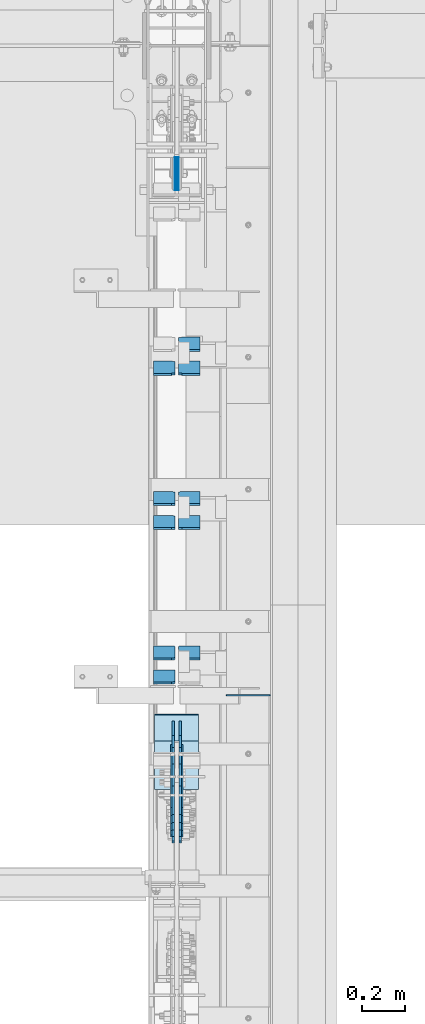
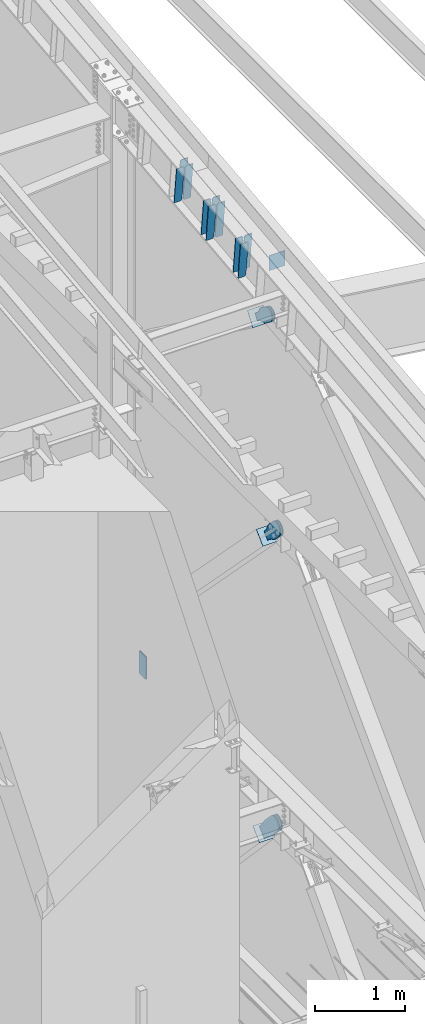
# One storey, part 1033 of 1179: 22 plates, 12 elements without a shape of their own.
"""IFC2X3 building model written with IfcOpenShell, lengths in millimetres."""

import ifcopenshell
import ifcopenshell.guid

model = None  # the IFC model being written
_history = None  # IfcOwnerHistory: only IFC2X3 demands one
_inside = {}  # id of a spatial element -> (the spatial element, [elements in it])
_under = {}  # id of a project, library or spatial element -> (it, [spatial elements below it])
_declared = {}  # id of a project -> (the project, [libraries it declares])
_typed = {}  # id of a type object -> (the type object, [elements of that type])
_made_of = {}  # id of a material, layer set ... -> (it, [elements and type objects made of it])


def new_model(schema):
    """Start an empty IFC model of exactly this schema.

    Asked for "IFC4X3", IfcOpenShell would pick the latest addendum, in which some entities
    have other attributes; the version numbers below select the first issue.
    IFC2X3 requires an IfcOwnerHistory on every rooted entity: one is made here for all.
    """
    global model, _history
    if schema == "IFC4X3":
        model = ifcopenshell.file(schema_version=(4, 3, 0, 0))
    else:
        model = ifcopenshell.file(schema=schema)
    _inside.clear()
    _under.clear()
    _declared.clear()
    _typed.clear()
    _made_of.clear()
    _history = None
    if model.schema == "IFC2X3":
        org = make("IfcOrganization", Name="unknown")
        user = make(
            "IfcPersonAndOrganization",
            ThePerson=make("IfcPerson", FamilyName="unknown"),
            TheOrganization=org,
        )
        app = make(
            "IfcApplication",
            ApplicationDeveloper=org,
            Version="unknown",
            ApplicationFullName="unknown",
            ApplicationIdentifier="unknown",
        )
        _history = make(
            "IfcOwnerHistory",
            OwningUser=user,
            OwningApplication=app,
            ChangeAction="ADDED",
            CreationDate=0,
        )
    return model


def make(cls, **values):
    """One entity of the class cls with the attributes given. An attribute that is None is left unset."""
    return model.create_entity(
        cls, **{name: value for name, value in values.items() if value is not None}
    )


def rooted(cls, **values):
    """An entity with a GlobalId (a new one), such as an element, a storey or a relation."""
    return make(cls, GlobalId=ifcopenshell.guid.new(), OwnerHistory=_history, **values)


def si_unit(unit_type, name, prefix=None):
    """IfcSIUnit, for example si_unit("LENGTHUNIT", "METRE", prefix="MILLI")."""
    return make("IfcSIUnit", UnitType=unit_type, Prefix=prefix, Name=name)


def assignment(units):
    """IfcUnitAssignment: the units of a project."""
    return None if units is None else make("IfcUnitAssignment", Units=units)


def point(xyz):
    """IfcCartesianPoint."""
    return None if xyz is None else make("IfcCartesianPoint", Coordinates=xyz)


def direction(xyz):
    """IfcDirection."""
    return None if xyz is None else make("IfcDirection", DirectionRatios=xyz)


def frame(location, z_axis=None, x_axis=None):
    """IfcAxis2Placement3D, a coordinate frame: its origin and axes. An axis left out is left unset."""
    return make(
        "IfcAxis2Placement3D",
        Location=point(location),
        Axis=direction(z_axis),
        RefDirection=direction(x_axis),
    )


def origin_with_axes():
    """The frame at (0, 0, 0) with the z axis (0, 0, 1) and the x axis (1, 0, 0) written out."""
    return frame((0.0, 0.0, 0.0), z_axis=(0.0, 0.0, 1.0), x_axis=(1.0, 0.0, 0.0))


def place(relative_to, where):
    """IfcLocalPlacement: puts the frame where relative to a parent placement (None: the world)."""
    return make(
        "IfcLocalPlacement", PlacementRelTo=relative_to, RelativePlacement=where
    )


def context(
    kind, dimensions, precision=None, world=None, true_north=None, identifier=None
):
    """IfcGeometricRepresentationContext, for example the 3D "Model" context."""
    return make(
        "IfcGeometricRepresentationContext",
        ContextIdentifier=identifier,
        ContextType=kind,
        CoordinateSpaceDimension=dimensions,
        Precision=precision,
        WorldCoordinateSystem=world,
        TrueNorth=true_north,
    )


def subcontext(parent, identifier, kind, view, scale=None):
    """IfcGeometricRepresentationSubContext, for example "Body" below "Model"."""
    return make(
        "IfcGeometricRepresentationSubContext",
        ContextIdentifier=identifier,
        ContextType=kind,
        ParentContext=parent,
        TargetScale=scale,
        TargetView=view,
    )


def project(units=None, contexts=None):
    """IfcProject with its units and contexts."""
    return rooted(
        "IfcProject",
        Name="project",
        RepresentationContexts=contexts,
        UnitsInContext=assignment(units),
    )


def spatial(cls, under=None, at=None, **own):
    """A site, building, storey or space (cls), placed at a placement, below another one or the project."""
    s = rooted(cls, ObjectPlacement=at, **own)
    if under is not None:
        _under.setdefault(under.id(), (under, []))[1].append(s)
    return s


def faces_of(points, faces, orient=None, outer=None):
    """IfcFace entities. A face is a list of loops; a loop is a list of indices into points, from 0.

    orient and outer hold one flag for each loop. By default every Orientation is true, the
    first loop of a face is its IfcFaceOuterBound and the others are IfcFaceBound.
    """
    made = []
    for i, loops in enumerate(faces):
        bounds = []
        for j, loop in enumerate(loops):
            is_outer = j == 0 if outer is None else outer[i][j]
            bounds.append(
                make(
                    "IfcFaceOuterBound" if is_outer else "IfcFaceBound",
                    Bound=make("IfcPolyLoop", Polygon=[points[k] for k in loop]),
                    Orientation=True if orient is None else orient[i][j],
                )
            )
        made.append(make("IfcFace", Bounds=bounds))
    return made


def faceted_brep(points, faces, orient=None, outer=None, voids=None):
    """IfcFacetedBrep: a solid bounded by flat faces; with voids (closed shells), ...WithVoids."""
    shared = [point(p) for p in points]
    hull = make("IfcClosedShell", CfsFaces=faces_of(shared, faces, orient, outer))
    if voids is None:
        return make("IfcFacetedBrep", Outer=hull)
    return make(
        "IfcFacetedBrepWithVoids",
        Outer=hull,
        Voids=[
            make(cls, CfsFaces=faces_of(shared, fs, o, b)) for cls, fs, o, b in voids
        ],
    )


def shape(context_of_items, identifier, shape_type, items):
    """IfcShapeRepresentation: the items that make up one representation, for example the "Body"."""
    return make(
        "IfcShapeRepresentation",
        ContextOfItems=context_of_items,
        RepresentationIdentifier=identifier,
        RepresentationType=shape_type,
        Items=items,
    )


def material(Name=None, Category=None):
    """IfcMaterial."""
    return make("IfcMaterial", Name=Name, Category=Category)


def made_of(thing, what):
    """Note that an element or type object is made of a material, layer set ...; save() writes the relation."""
    if what is not None:
        _made_of.setdefault(what.id(), (what, []))[1].append(thing)
    return thing


def type_object(cls, material=None, **own):
    """A type object (cls), such as IfcWallType, which elements share."""
    return made_of(rooted(cls, **own), material)


def element(
    cls,
    number,
    at=None,
    inside=None,
    cuts=None,
    type_object=None,
    material=None,
    context=None,
    identifier="Body",
    shape_type=None,
    held_by="IfcProductDefinitionShape",
    body=None,
    shapes=None,
    **own,
):
    """One element of the class cls, such as IfcWall. Its Tag is "e" and its number.

    at: its placement. inside: the storey or other place that contains it. cuts: it is an
    opening in that element (IfcRelVoidsElement). A single representation is given by context,
    identifier, shape_type and body (its items); several are given by shapes. held_by: the class
    of the entity that holds the representations. save() writes the other relations.
    """
    e = rooted(cls, Tag="e%d" % number, ObjectPlacement=at, **own)
    if body is not None:
        shapes = [shape(context, identifier, shape_type, body)]
    if shapes is not None:
        e.Representation = make(held_by, Representations=shapes)
    if inside is not None:
        _inside.setdefault(inside.id(), (inside, []))[1].append(e)
    if cuts is not None:
        rooted(
            "IfcRelVoidsElement", RelatingBuildingElement=cuts, RelatedOpeningElement=e
        )
    if type_object is not None:
        _typed.setdefault(type_object.id(), (type_object, []))[1].append(e)
    return made_of(e, material)


def aggregate(whole, parts):
    """IfcRelAggregates: a whole, such as a stair, and the parts it consists of."""
    return rooted("IfcRelAggregates", RelatingObject=whole, RelatedObjects=parts)


def save(model, path):
    """Write the relations noted so far, then the file.

    IfcRelAggregates (storeys below a building ...), IfcRelContainedInSpatialStructure (elements
    in a storey), IfcRelDefinesByType, IfcRelAssociatesMaterial and IfcRelDeclares: one each for
    every whole, place, type object, material and project.
    """
    for whole, parts in _under.values():
        aggregate(whole, parts)
    for where, things in _inside.values():
        rooted(
            "IfcRelContainedInSpatialStructure",
            RelatedElements=things,
            RelatingStructure=where,
        )
    for kind, things in _typed.values():
        rooted("IfcRelDefinesByType", RelatedObjects=things, RelatingType=kind)
    for what, things in _made_of.values():
        rooted("IfcRelAssociatesMaterial", RelatedObjects=things, RelatingMaterial=what)
    for by, libraries in _declared.values():
        rooted("IfcRelDeclares", RelatingContext=by, RelatedDefinitions=libraries)
    model.write(path)


model = new_model("IFC2X3")

# Units and contexts
model_context = context("Model", 3, precision=1e-05, world=origin_with_axes())
body_context = subcontext(model_context, "Body", "Model", "MODEL_VIEW")
ifc_project = project(units=[si_unit("LENGTHUNIT", "METRE", prefix="MILLI"), si_unit("AREAUNIT", "SQUARE_METRE"), si_unit("VOLUMEUNIT", "CUBIC_METRE"), si_unit("MASSUNIT", "GRAM", prefix="KILO"), si_unit("TIMEUNIT", "SECOND"), si_unit("PLANEANGLEUNIT", "RADIAN"), si_unit("SOLIDANGLEUNIT", "STERADIAN"), si_unit("THERMODYNAMICTEMPERATUREUNIT", "DEGREE_CELSIUS"), si_unit("LUMINOUSINTENSITYUNIT", "LUMEN")], contexts=[model_context])

# Site, building, storey
site_placement = place(None, origin_with_axes())
site = spatial("IfcSite", under=ifc_project, at=site_placement, CompositionType="ELEMENT")
building_placement = place(site_placement, origin_with_axes())
building = spatial("IfcBuilding", under=site, at=building_placement, Name="Undefined", CompositionType="ELEMENT")
storey_placement = place(building_placement, origin_with_axes())
storey = spatial("IfcBuildingStorey", under=building, at=storey_placement, Name="Undefined", CompositionType="ELEMENT", Elevation=0.0)

# Assembly, plate
assembly_1_placement = place(storey_placement, origin_with_axes())
assembly_1 = element("IfcElementAssembly", 1, at=assembly_1_placement, inside=storey, AssemblyPlace="NOTDEFINED", PredefinedType="RIGID_FRAME")
ifc_material_1 = material(Name="STEEL/A36")
plate_type_1 = type_object("IfcPlateType", PredefinedType="NOTDEFINED")
plate_1_placement = place(assembly_1_placement, frame((24291.925, 16048.2486590717, 10252.7896659957), z_axis=(0.0, -0.591857899923171, -0.806042322895352), x_axis=(0.0, 0.806042322895357, -0.591857899923163)))
plate_1 = element("IfcPlate", 2, at=plate_1_placement, type_object=plate_type_1, material=ifc_material_1, context=body_context, shape_type="Brep", body=[
    faceted_brep([(0.0, -6.34999999999854, 0.0), (-101.600000000211, -6.34999999999854, -44.6881937825565), (-101.600000000211, 6.34999999999854, -44.6881937825565), (0.0, 6.34999999999854, 0.0), (-246.684985848258, -6.34999999999854, -44.6881937827675), (-246.684985848258, 6.34999999999854, -44.6881937827675), (-281.313054102191, -6.34999999999854, -37.800242748639), (-281.313054102191, 6.34999999999854, -37.800242748639), (-310.669312868691, -6.34999999999854, -18.1850177516608), (-310.669312868691, 6.34999999999854, -18.1850177516608), (-330.284537865713, -6.34999999999854, 11.1712410148393), (-330.284537865713, 6.34999999999854, 11.1712410148393), (-337.172488899912, -6.34999999999854, 45.7993031647638), (-337.172488899912, 6.34999999999854, 45.7993031647638), (-330.284537865768, -6.34999999999854, 80.4273714187839), (-330.284537865768, 6.34999999999854, 80.4273714187839), (-310.669312868773, -6.34999999999854, 109.783630185371), (-310.669312868773, 6.34999999999854, 109.783630185371), (-281.313054102271, -6.34999999999854, 129.398855182466), (-281.313054102271, 6.34999999999854, 129.398855182466), (-246.684988899762, -6.34999999999854, 136.286806216707), (-246.684988899762, 6.34999999999854, 136.286806216707), (-101.600000000377, -6.34999999999854, 136.286806216911), (-101.600000000377, 6.34999999999854, 136.286806216911), (-8.18545231595635e-11, -6.34999999999854, 91.5986124346418), (-8.18545231595635e-11, 6.34999999999854, 91.5986124346418), (82.5500000001266, -6.34999999999854, 91.5986124347546), (82.5500000001266, 6.34999999999854, 91.5986124347546), (82.550000000203, -6.34999999999854, 1.2732925824821e-10), (82.550000000203, 6.34999999999854, 1.2732925824821e-10)], [[[0, 1, 2, 3]], [[1, 4, 5, 2]], [[4, 6, 7, 5]], [[6, 8, 9, 7]], [[8, 10, 11, 9]], [[10, 12, 13, 11]], [[12, 14, 15, 13]], [[14, 16, 17, 15]], [[16, 18, 19, 17]], [[18, 20, 21, 19]], [[20, 22, 23, 21]], [[22, 24, 25, 23]], [[24, 26, 27, 25]], [[26, 28, 29, 27]], [[28, 0, 3, 29]], [[5, 7, 9, 11, 13, 15, 17, 19, 21, 23, 25, 27, 29, 3, 2]], [[28, 26, 24, 22, 20, 18, 16, 14, 12, 10, 8, 6, 4, 1, 0]]]),
])
aggregate(assembly_1, [plate_1])

assembly_2_placement = place(storey_placement, origin_with_axes())
assembly_2 = element("IfcElementAssembly", 3, at=assembly_2_placement, inside=storey, AssemblyPlace="NOTDEFINED", PredefinedType="RIGID_FRAME")
plate_2_placement = place(assembly_2_placement, frame((24323.675, 16048.2486590717, 10252.7896659957), z_axis=(0.0, -0.591857899923171, -0.806042322895352), x_axis=(0.0, 0.806042322895357, -0.591857899923163)))
plate_2 = element("IfcPlate", 4, at=plate_2_placement, type_object=plate_type_1, material=ifc_material_1, context=body_context, shape_type="Brep", body=[
    faceted_brep([(0.0, -6.34999999999854, 0.0), (-101.600000000211, -6.34999999999854, -44.6881937825565), (-101.600000000211, 6.34999999999854, -44.6881937825565), (0.0, 6.34999999999854, 0.0), (-246.684985848258, -6.34999999999854, -44.6881937827675), (-246.684985848258, 6.34999999999854, -44.6881937827675), (-281.313054102191, -6.34999999999854, -37.800242748639), (-281.313054102191, 6.34999999999854, -37.800242748639), (-310.669312868691, -6.34999999999854, -18.1850177516608), (-310.669312868691, 6.34999999999854, -18.1850177516608), (-330.284537865713, -6.34999999999854, 11.1712410148393), (-330.284537865713, 6.34999999999854, 11.1712410148393), (-337.172488899912, -6.34999999999854, 45.7993031647638), (-337.172488899912, 6.34999999999854, 45.7993031647638), (-330.284537865768, -6.34999999999854, 80.4273714187839), (-330.284537865768, 6.34999999999854, 80.4273714187839), (-310.669312868773, -6.34999999999854, 109.783630185371), (-310.669312868773, 6.34999999999854, 109.783630185371), (-281.313054102271, -6.34999999999854, 129.398855182466), (-281.313054102271, 6.34999999999854, 129.398855182466), (-246.684988899762, -6.34999999999854, 136.286806216707), (-246.684988899762, 6.34999999999854, 136.286806216707), (-101.600000000377, -6.34999999999854, 136.286806216911), (-101.600000000377, 6.34999999999854, 136.286806216911), (-8.18545231595635e-11, -6.34999999999854, 91.5986124346418), (-8.18545231595635e-11, 6.34999999999854, 91.5986124346418), (82.5500000001266, -6.34999999999854, 91.5986124347546), (82.5500000001266, 6.34999999999854, 91.5986124347546), (82.550000000203, -6.34999999999854, 1.2732925824821e-10), (82.550000000203, 6.34999999999854, 1.2732925824821e-10)], [[[0, 1, 2, 3]], [[1, 4, 5, 2]], [[4, 6, 7, 5]], [[6, 8, 9, 7]], [[8, 10, 11, 9]], [[10, 12, 13, 11]], [[12, 14, 15, 13]], [[14, 16, 17, 15]], [[16, 18, 19, 17]], [[18, 20, 21, 19]], [[20, 22, 23, 21]], [[22, 24, 25, 23]], [[24, 26, 27, 25]], [[26, 28, 29, 27]], [[28, 0, 3, 29]], [[5, 7, 9, 11, 13, 15, 17, 19, 21, 23, 25, 27, 29, 3, 2]], [[28, 26, 24, 22, 20, 18, 16, 14, 12, 10, 8, 6, 4, 1, 0]]]),
])
aggregate(assembly_2, [plate_2])

assembly_3_placement = place(storey_placement, origin_with_axes())
assembly_3 = element("IfcElementAssembly", 5, at=assembly_3_placement, inside=storey, Name="BEAM", AssemblyPlace="NOTDEFINED", PredefinedType="RIGID_FRAME")
plate_type_2 = type_object("IfcPlateType", PredefinedType="NOTDEFINED")
plate_3_placement = place(assembly_3_placement, frame((24739.6, 16233.775, 10824.825825947), z_axis=(0.0, 0.0, -1.0), x_axis=(-1.0, 0.0, 0.0)))
plate_3 = element("IfcPlate", 6, at=plate_3_placement, type_object=plate_type_2, material=ifc_material_1, Name="CAP_PLATE", context=body_context, shape_type="Brep", body=[
    faceted_brep([(0.0, -3.17500000000109, 0.0), (0.0, -3.17499999999927, 204.492999998953), (0.0, 3.17499999999927, 204.492999998953), (0.0, 3.17500000000109, 7.27595761418343e-12), (203.199999999997, -3.17499999999927, 204.492999998953), (203.199999999997, 3.17499999999927, 204.492999998953), (203.199999999997, -3.17499999999927, 3.63797880709171e-12), (203.199999999997, 3.17499999999382, -3.63797880709171e-12)], [[[0, 1, 2, 3]], [[1, 4, 5, 2]], [[4, 6, 7, 5]], [[6, 0, 3, 7]], [[5, 7, 3, 2]], [[6, 4, 1, 0]]]),
])
aggregate(assembly_3, [plate_3])

assembly_4_placement = place(storey_placement, origin_with_axes())
assembly_4 = element("IfcElementAssembly", 7, at=assembly_4_placement, inside=storey, Name="Plate", AssemblyPlace="NOTDEFINED", PredefinedType="RIGID_FRAME")
plate_4_placement = place(assembly_4_placement, frame((24206.2, 16024.9888246272, 10087.00086601), z_axis=(0.0, 0.591857899923162, 0.806042322895358), x_axis=(1.0, 0.0, 0.0)))
plate_4 = element("IfcPlate", 8, at=plate_4_placement, type_object=plate_type_2, material=ifc_material_1, Name="Plate", context=body_context, shape_type="Brep", body=[
    faceted_brep([(0.0, -3.17500000000109, 0.0), (0.0, -3.17500000000291, 203.200000000368), (0.0, 3.17499999998836, 203.200000000361), (0.0, 3.17500000000109, 7.27595761418343e-12), (203.199999999997, -3.17500000000291, 203.200000000368), (203.199999999997, 3.17499999998836, 203.200000000361), (203.199999999997, -3.17499999999927, 3.63797880709171e-12), (203.199999999997, 3.17499999999382, -3.63797880709171e-12)], [[[0, 1, 2, 3]], [[1, 4, 5, 2]], [[4, 6, 7, 5]], [[6, 0, 3, 7]], [[5, 7, 3, 2]], [[6, 4, 1, 0]]]),
])
aggregate(assembly_4, [plate_4])

assembly_5_placement = place(storey_placement, origin_with_axes())
assembly_5 = element("IfcElementAssembly", 9, at=assembly_5_placement, inside=storey, Name="Plate", AssemblyPlace="NOTDEFINED", PredefinedType="RIGID_FRAME")
plate_5_placement = place(assembly_5_placement, frame((24206.2, 15801.1352561086, 7258.01555814553), z_axis=(0.0, 0.71564233903776, 0.698466923036849), x_axis=(1.0, 0.0, 0.0)))
plate_5 = element("IfcPlate", 10, at=plate_5_placement, type_object=plate_type_2, material=ifc_material_1, Name="Plate", context=body_context, shape_type="Brep", body=[
    faceted_brep([(0.0, -3.17500000000109, 0.0), (0.0, -3.17500000000291, 203.200000000368), (0.0, 3.17499999998836, 203.200000000361), (0.0, 3.17500000000109, 7.27595761418343e-12), (203.199999999997, -3.17500000000291, 203.200000000368), (203.199999999997, 3.17499999998836, 203.200000000361), (203.199999999997, -3.17499999999927, 3.63797880709171e-12), (203.199999999997, 3.17499999999382, -3.63797880709171e-12)], [[[0, 1, 2, 3]], [[1, 4, 5, 2]], [[4, 6, 7, 5]], [[6, 0, 3, 7]], [[5, 7, 3, 2]], [[6, 4, 1, 0]]]),
])
aggregate(assembly_5, [plate_5])

assembly_6_placement = place(storey_placement, origin_with_axes())
assembly_6 = element("IfcElementAssembly", 11, at=assembly_6_placement, inside=storey, Name="Plate", AssemblyPlace="NOTDEFINED", PredefinedType="RIGID_FRAME")
plate_6_placement = place(assembly_6_placement, frame((24206.2, 15877.3775325798, 3189.63896334256), z_axis=(0.0, 0.727605443744036, 0.68599585875867), x_axis=(1.0, 0.0, 0.0)))
plate_6 = element("IfcPlate", 12, at=plate_6_placement, type_object=plate_type_2, material=ifc_material_1, Name="Plate", context=body_context, shape_type="Brep", body=[
    faceted_brep([(0.0, -3.17500000000109, 0.0), (0.0, -3.17500000000291, 203.200000000368), (0.0, 3.17499999998836, 203.200000000361), (0.0, 3.17500000000109, 7.27595761418343e-12), (203.199999999997, -3.17500000000291, 203.200000000368), (203.199999999997, 3.17499999998836, 203.200000000361), (203.199999999997, -3.17499999999927, 3.63797880709171e-12), (203.199999999997, 3.17499999999382, -3.63797880709171e-12)], [[[0, 1, 2, 3]], [[1, 4, 5, 2]], [[4, 6, 7, 5]], [[6, 0, 3, 7]], [[5, 7, 3, 2]], [[6, 4, 1, 0]]]),
])
aggregate(assembly_6, [plate_6])

# Assembly, plates
assembly_7_placement = place(storey_placement, origin_with_axes())
assembly_7 = element("IfcElementAssembly", 13, at=assembly_7_placement, inside=storey, Name="BEAM", AssemblyPlace="NOTDEFINED", PredefinedType="RIGID_FRAME")
ifc_material_2 = material(Name="STEEL/A572-GR.50")
plate_type_3 = type_object("IfcPlateType", PredefinedType="NOTDEFINED")
plate_7_placement = place(assembly_7_placement, frame((24300.65625, 18562.3015666254, 4044.95), z_axis=(0.0, 0.0, -1.0), x_axis=(0.0, 1.0, 0.0)))
plate_7 = element("IfcPlate", 14, at=plate_7_placement, type_object=plate_type_3, material=ifc_material_2, Name="PLATE", context=body_context, shape_type="Brep", body=[
    faceted_brep([(3.63797880709171e-12, -1.58750000000055, 1.81898940354586e-12), (-2.18278728425503e-11, -1.58750000000146, 304.8), (-2.18278728425503e-11, 1.58750000000146, 304.8), (-3.63797880709171e-12, 1.58750000000055, 0.0), (152.399999999994, -1.58750000000146, 304.8), (152.399999999994, 1.58750000000146, 304.8), (152.399999999994, -1.58750000000146, 0.0), (152.399999999994, 1.58750000000146, 0.0)], [[[0, 1, 2, 3]], [[1, 4, 5, 2]], [[4, 6, 7, 5]], [[6, 0, 3, 7]], [[5, 7, 3, 2]], [[6, 4, 1, 0]]]),
])
plate_8_placement = place(assembly_7_placement, frame((24314.94375, 18562.3015666254, 4044.95), z_axis=(0.0, 0.0, -1.0), x_axis=(0.0, 1.0, 0.0)))
plate_8 = element("IfcPlate", 15, at=plate_8_placement, type_object=plate_type_3, material=ifc_material_2, Name="PLATE", context=body_context, shape_type="Brep", body=[
    faceted_brep([(3.63797880709171e-12, -1.58750000000055, 1.81898940354586e-12), (-2.18278728425503e-11, -1.58750000000146, 304.8), (-2.18278728425503e-11, 1.58750000000146, 304.8), (-3.63797880709171e-12, 1.58750000000055, 0.0), (152.399999999994, -1.58750000000146, 304.8), (152.399999999994, 1.58750000000146, 304.8), (152.399999999994, -1.58750000000146, 0.0), (152.399999999994, 1.58750000000146, 0.0)], [[[0, 1, 2, 3]], [[1, 4, 5, 2]], [[4, 6, 7, 5]], [[6, 0, 3, 7]], [[5, 7, 3, 2]], [[6, 4, 1, 0]]]),
])
aggregate(assembly_7, [plate_7, plate_8])

assembly_8_placement = place(storey_placement, origin_with_axes())
assembly_8 = element("IfcElementAssembly", 16, at=assembly_8_placement, inside=storey, Name="BEAM", AssemblyPlace="NOTDEFINED", PredefinedType="RIGID_FRAME")
plate_type_4 = type_object("IfcPlateType", PredefinedType="NOTDEFINED")
plate_9_placement = place(assembly_8_placement, frame((24300.65625, 16346.2342144593, 10566.7739249366), z_axis=(0.0, -0.112284087038017, 0.993676146336441), x_axis=(-1.0, 0.0, 0.0)))
plate_9 = element("IfcPlate", 17, at=plate_9_placement, type_object=plate_type_4, material=ifc_material_1, Name="PLATE", context=body_context, shape_type="Brep", body=[
    faceted_brep([(-1.81898940354586e-12, -4.76249999999345, 17.4624996185303), (0.0, -4.76250000019354, 481.012500380073), (0.0, 4.76249999980064, 481.012500380079), (1.81898940354586e-12, 4.76250000000073, 17.4624996185303), (17.4624996185303, -4.76250000020082, 498.474999998594), (17.4624996185303, 4.76249999979336, 498.474999998596), (99.2187497618652, -4.76249999998072, 498.475), (99.2187499999927, 4.76250000001892, 498.475), (99.21875, -4.76250000000073, 0.0), (99.21875, 4.76249999999709, 3.63797880709171e-12), (17.4624996185157, -4.76250000000073, 0.0), (17.4624996185212, 4.76249999999345, 0.0)], [[[0, 1, 2, 3]], [[1, 4, 5, 2]], [[4, 6, 7, 5]], [[6, 8, 9, 7]], [[8, 10, 11, 9]], [[10, 0, 3, 11]], [[5, 7, 9, 11, 3, 2]], [[10, 8, 6, 4, 1, 0]]]),
])
plate_10_placement = place(assembly_8_placement, frame((24414.1625, 16456.6564762209, 10579.2514941086), z_axis=(0.0, -0.112284087038017, 0.993676146336441), x_axis=(-1.0, 0.0, 0.0)))
plate_10 = element("IfcPlate", 18, at=plate_10_placement, type_object=plate_type_4, material=ifc_material_1, Name="PLATE", context=body_context, shape_type="Brep", body=[
    faceted_brep([(0.0, -4.76249999999709, 0.0), (0.0, -4.76250000020082, 498.474999998594), (0.0, 4.76249999979336, 498.474999998596), (0.0, 4.76249999999709, 0.0), (81.7562503814697, -4.76250000020082, 498.474999998594), (81.7562503814697, 4.76249999979336, 498.474999998596), (99.21875, -4.76250000019354, 481.012500380073), (99.21875, 4.76249999980064, 481.012500380079), (99.21875, -4.76250000000437, 17.4624996185212), (99.21875, 4.76249999998981, 17.4624996185248), (81.7562503814697, -4.76250000000073, 0.0), (81.7562503814697, 4.76249999999709, 3.63797880709171e-12)], [[[0, 1, 2, 3]], [[1, 4, 5, 2]], [[4, 6, 7, 5]], [[6, 8, 9, 7]], [[8, 10, 11, 9]], [[10, 0, 3, 11]], [[5, 7, 9, 11, 3, 2]], [[10, 8, 6, 4, 1, 0]]]),
])
plate_11_placement = place(assembly_8_placement, frame((24300.65625, 16456.6564762209, 10579.2514941086), z_axis=(0.0, -0.112284087038017, 0.993676146336441), x_axis=(-1.0, 0.0, 0.0)))
plate_11 = element("IfcPlate", 19, at=plate_11_placement, type_object=plate_type_4, material=ifc_material_1, Name="PLATE", context=body_context, shape_type="Brep", body=[
    faceted_brep([(-1.81898940354586e-12, -4.76249999999345, 17.4624996185303), (0.0, -4.76250000019354, 481.012500380073), (0.0, 4.76249999980064, 481.012500380079), (1.81898940354586e-12, 4.76250000000073, 17.4624996185303), (17.4624996185303, -4.76250000020082, 498.474999998594), (17.4624996185303, 4.76249999979336, 498.474999998596), (99.2187497618652, -4.76249999998072, 498.475), (99.2187499999927, 4.76250000001892, 498.475), (99.21875, -4.76250000000073, 0.0), (99.21875, 4.76249999999709, 3.63797880709171e-12), (17.4624996185157, -4.76250000000073, 0.0), (17.4624996185212, 4.76249999999345, 0.0)], [[[0, 1, 2, 3]], [[1, 4, 5, 2]], [[4, 6, 7, 5]], [[6, 8, 9, 7]], [[8, 10, 11, 9]], [[10, 0, 3, 11]], [[5, 7, 9, 11, 3, 2]], [[10, 8, 6, 4, 1, 0]]]),
])
plate_12_placement = place(assembly_8_placement, frame((24414.1625, 17057.871349427, 10647.1879776403), z_axis=(0.0, -0.112284087038017, 0.993676146336441), x_axis=(-1.0, 0.0, 0.0)))
plate_12 = element("IfcPlate", 20, at=plate_12_placement, type_object=plate_type_4, material=ifc_material_1, Name="PLATE", context=body_context, shape_type="Brep", body=[
    faceted_brep([(0.0, -4.76249999999709, 0.0), (0.0, -4.76250000020082, 498.474999998594), (0.0, 4.76249999979336, 498.474999998596), (0.0, 4.76249999999709, 0.0), (81.7562503814697, -4.76250000020082, 498.474999998594), (81.7562503814697, 4.76249999979336, 498.474999998596), (99.21875, -4.76250000019354, 481.012500380073), (99.21875, 4.76249999980064, 481.012500380079), (99.21875, -4.76250000000437, 17.4624996185212), (99.21875, 4.76249999998981, 17.4624996185248), (81.7562503814697, -4.76250000000073, 0.0), (81.7562503814697, 4.76249999999709, 3.63797880709171e-12)], [[[0, 1, 2, 3]], [[1, 4, 5, 2]], [[4, 6, 7, 5]], [[6, 8, 9, 7]], [[8, 10, 11, 9]], [[10, 0, 3, 11]], [[5, 7, 9, 11, 3, 2]], [[10, 8, 6, 4, 1, 0]]]),
])
plate_13_placement = place(assembly_8_placement, frame((24300.65625, 17057.871349427, 10647.1879776403), z_axis=(0.0, -0.112284087038017, 0.993676146336441), x_axis=(-1.0, 0.0, 0.0)))
plate_13 = element("IfcPlate", 21, at=plate_13_placement, type_object=plate_type_4, material=ifc_material_1, Name="PLATE", context=body_context, shape_type="Brep", body=[
    faceted_brep([(-1.81898940354586e-12, -4.76249999999345, 17.4624996185303), (0.0, -4.76250000019354, 481.012500380073), (0.0, 4.76249999980064, 481.012500380079), (1.81898940354586e-12, 4.76250000000073, 17.4624996185303), (17.4624996185303, -4.76250000020082, 498.474999998594), (17.4624996185303, 4.76249999979336, 498.474999998596), (99.2187497618652, -4.76249999998072, 498.475), (99.2187499999927, 4.76250000001892, 498.475), (99.21875, -4.76250000000073, 0.0), (99.21875, 4.76249999999709, 3.63797880709171e-12), (17.4624996185157, -4.76250000000073, 0.0), (17.4624996185212, 4.76249999999345, 0.0)], [[[0, 1, 2, 3]], [[1, 4, 5, 2]], [[4, 6, 7, 5]], [[6, 8, 9, 7]], [[8, 10, 11, 9]], [[10, 0, 3, 11]], [[5, 7, 9, 11, 3, 2]], [[10, 8, 6, 4, 1, 0]]]),
])
plate_14_placement = place(assembly_8_placement, frame((24414.1625, 17168.2936111885, 10659.6655468123), z_axis=(0.0, -0.112284087038017, 0.993676146336441), x_axis=(-1.0, 0.0, 0.0)))
plate_14 = element("IfcPlate", 22, at=plate_14_placement, type_object=plate_type_4, material=ifc_material_1, Name="PLATE", context=body_context, shape_type="Brep", body=[
    faceted_brep([(0.0, -4.76249999999709, 0.0), (0.0, -4.76250000020082, 498.474999998594), (0.0, 4.76249999979336, 498.474999998596), (0.0, 4.76249999999709, 0.0), (81.7562503814697, -4.76250000020082, 498.474999998594), (81.7562503814697, 4.76249999979336, 498.474999998596), (99.21875, -4.76250000019354, 481.012500380073), (99.21875, 4.76249999980064, 481.012500380079), (99.21875, -4.76250000000437, 17.4624996185212), (99.21875, 4.76249999998981, 17.4624996185248), (81.7562503814697, -4.76250000000073, 0.0), (81.7562503814697, 4.76249999999709, 3.63797880709171e-12)], [[[0, 1, 2, 3]], [[1, 4, 5, 2]], [[4, 6, 7, 5]], [[6, 8, 9, 7]], [[8, 10, 11, 9]], [[10, 0, 3, 11]], [[5, 7, 9, 11, 3, 2]], [[10, 8, 6, 4, 1, 0]]]),
])
plate_15_placement = place(assembly_8_placement, frame((24300.65625, 17168.2936111885, 10659.6655468123), z_axis=(0.0, -0.112284087038017, 0.993676146336441), x_axis=(-1.0, 0.0, 0.0)))
plate_15 = element("IfcPlate", 23, at=plate_15_placement, type_object=plate_type_4, material=ifc_material_1, Name="PLATE", context=body_context, shape_type="Brep", body=[
    faceted_brep([(-1.81898940354586e-12, -4.76249999999345, 17.4624996185303), (0.0, -4.76250000019354, 481.012500380073), (0.0, 4.76249999980064, 481.012500380079), (1.81898940354586e-12, 4.76250000000073, 17.4624996185303), (17.4624996185303, -4.76250000020082, 498.474999998594), (17.4624996185303, 4.76249999979336, 498.474999998596), (99.2187497618652, -4.76249999998072, 498.475), (99.2187499999927, 4.76250000001892, 498.475), (99.21875, -4.76250000000073, 0.0), (99.21875, 4.76249999999709, 3.63797880709171e-12), (17.4624996185157, -4.76250000000073, 0.0), (17.4624996185212, 4.76249999999345, 0.0)], [[[0, 1, 2, 3]], [[1, 4, 5, 2]], [[4, 6, 7, 5]], [[6, 8, 9, 7]], [[8, 10, 11, 9]], [[10, 0, 3, 11]], [[5, 7, 9, 11, 3, 2]], [[10, 8, 6, 4, 1, 0]]]),
])
plate_16_placement = place(assembly_8_placement, frame((24414.1625, 17769.5084843946, 10727.602030344), z_axis=(0.0, -0.112284087038017, 0.993676146336441), x_axis=(-1.0, 0.0, 0.0)))
plate_16 = element("IfcPlate", 24, at=plate_16_placement, type_object=plate_type_4, material=ifc_material_1, Name="PLATE", context=body_context, shape_type="Brep", body=[
    faceted_brep([(0.0, -4.76249999999709, 0.0), (0.0, -4.76250000020082, 498.474999998594), (0.0, 4.76249999979336, 498.474999998596), (0.0, 4.76249999999709, 0.0), (81.7562503814697, -4.76250000020082, 498.474999998594), (81.7562503814697, 4.76249999979336, 498.474999998596), (99.21875, -4.76250000019354, 481.012500380073), (99.21875, 4.76249999980064, 481.012500380079), (99.21875, -4.76250000000437, 17.4624996185212), (99.21875, 4.76249999998981, 17.4624996185248), (81.7562503814697, -4.76250000000073, 0.0), (81.7562503814697, 4.76249999999709, 3.63797880709171e-12)], [[[0, 1, 2, 3]], [[1, 4, 5, 2]], [[4, 6, 7, 5]], [[6, 8, 9, 7]], [[8, 10, 11, 9]], [[10, 0, 3, 11]], [[5, 7, 9, 11, 3, 2]], [[10, 8, 6, 4, 1, 0]]]),
])
plate_17_placement = place(assembly_8_placement, frame((24300.65625, 17769.5084843946, 10727.602030344), z_axis=(0.0, -0.112284087038017, 0.993676146336441), x_axis=(-1.0, 0.0, 0.0)))
plate_17 = element("IfcPlate", 25, at=plate_17_placement, type_object=plate_type_4, material=ifc_material_1, Name="PLATE", context=body_context, shape_type="Brep", body=[
    faceted_brep([(-1.81898940354586e-12, -4.76249999999345, 17.4624996185303), (0.0, -4.76250000019354, 481.012500380073), (0.0, 4.76249999980064, 481.012500380079), (1.81898940354586e-12, 4.76250000000073, 17.4624996185303), (17.4624996185303, -4.76250000020082, 498.474999998594), (17.4624996185303, 4.76249999979336, 498.474999998596), (99.2187497618652, -4.76249999998072, 498.475), (99.2187499999927, 4.76250000001892, 498.475), (99.21875, -4.76250000000073, 0.0), (99.21875, 4.76249999999709, 3.63797880709171e-12), (17.4624996185157, -4.76250000000073, 0.0), (17.4624996185212, 4.76249999999345, 0.0)], [[[0, 1, 2, 3]], [[1, 4, 5, 2]], [[4, 6, 7, 5]], [[6, 8, 9, 7]], [[8, 10, 11, 9]], [[10, 0, 3, 11]], [[5, 7, 9, 11, 3, 2]], [[10, 8, 6, 4, 1, 0]]]),
])
plate_18_placement = place(assembly_8_placement, frame((24414.1625, 17879.9307461562, 10740.079599516), z_axis=(0.0, -0.112284087038017, 0.993676146336441), x_axis=(-1.0, 0.0, 0.0)))
plate_18 = element("IfcPlate", 26, at=plate_18_placement, type_object=plate_type_4, material=ifc_material_1, Name="PLATE", context=body_context, shape_type="Brep", body=[
    faceted_brep([(0.0, -4.76249999999709, 0.0), (0.0, -4.76250000020082, 498.474999998594), (0.0, 4.76249999979336, 498.474999998596), (0.0, 4.76249999999709, 0.0), (81.7562503814697, -4.76250000020082, 498.474999998594), (81.7562503814697, 4.76249999979336, 498.474999998596), (99.21875, -4.76250000019354, 481.012500380073), (99.21875, 4.76249999980064, 481.012500380079), (99.21875, -4.76250000000437, 17.4624996185212), (99.21875, 4.76249999998981, 17.4624996185248), (81.7562503814697, -4.76250000000073, 0.0), (81.7562503814697, 4.76249999999709, 3.63797880709171e-12)], [[[0, 1, 2, 3]], [[1, 4, 5, 2]], [[4, 6, 7, 5]], [[6, 8, 9, 7]], [[8, 10, 11, 9]], [[10, 0, 3, 11]], [[5, 7, 9, 11, 3, 2]], [[10, 8, 6, 4, 1, 0]]]),
])
aggregate(assembly_8, [plate_9, plate_10, plate_11, plate_12, plate_13, plate_14, plate_15, plate_16, plate_17, plate_18])

# Assembly, plate
assembly_9_placement = place(storey_placement, origin_with_axes())
assembly_9 = element("IfcElementAssembly", 27, at=assembly_9_placement, inside=storey, AssemblyPlace="NOTDEFINED", PredefinedType="RIGID_FRAME")
plate_type_5 = type_object("IfcPlateType", PredefinedType="NOTDEFINED")
plate_19_placement = place(assembly_9_placement, frame((24291.925, 15858.5458488829, 7424.96263990472), z_axis=(0.0, -0.715642339037757, -0.698466923036852), x_axis=(0.0, 0.698466923036852, -0.715642339037758)))
plate_19 = element("IfcPlate", 28, at=plate_19_placement, type_object=plate_type_5, material=ifc_material_1, context=body_context, shape_type="Brep", body=[
    faceted_brep([(0.0, -6.34999999999854, 0.0), (-101.599999999963, -6.34999999999854, -37.5700345970108), (-101.599999999963, 6.34999999999854, -37.5700345970108), (0.0, 6.34999999999854, 0.0), (-245.369242323884, -6.34999999999854, -37.5700345970945), (-245.369242323884, 6.34999999999854, -37.5700345970945), (-281.212328723803, -6.34999999999854, -30.4404014271258), (-281.212328723803, 6.34999999999854, -30.4404014271258), (-311.598630137756, -6.34999999999854, -10.1369239370142), (-311.598630137756, 6.34999999999854, -10.1369239370142), (-331.902107627997, -6.34999999999854, 20.24937747687), (-331.902107627997, 6.34999999999854, 20.24937747687), (-339.031740798124, -6.34999999999854, 56.0924669287269), (-339.031740798124, 6.34999999999854, 56.0924669287269), (-331.902107628228, -6.34999999999854, 91.9355533287926), (-331.902107628228, 6.34999999999854, 91.9355533287926), (-311.598630138099, -6.34999999999854, 122.321854742866), (-311.598630138099, 6.34999999999854, 122.321854742866), (-281.212328724136, -6.34999999999854, 142.625332233139), (-281.212328724136, 6.34999999999854, 142.625332233139), (-245.36924079839, -6.34999999999854, 149.754965403199), (-245.36924079839, 6.34999999999854, 149.754965403199), (-101.600000000685, -6.34999999999854, 149.75496540329), (-101.600000000685, 6.34999999999854, 149.75496540329), (-4.35647962149233e-10, -6.34999999999854, 112.184930806416), (-4.35647962149233e-10, 6.34999999999854, 112.184930806416), (82.5499999996491, -6.34999999999854, 112.184930806461), (82.5499999996491, 6.34999999999854, 112.184930806461), (82.550000000203, -6.34999999999854, 1.2732925824821e-10), (82.550000000203, 6.34999999999854, 1.2732925824821e-10)], [[[0, 1, 2, 3]], [[1, 4, 5, 2]], [[4, 6, 7, 5]], [[6, 8, 9, 7]], [[8, 10, 11, 9]], [[10, 12, 13, 11]], [[12, 14, 15, 13]], [[14, 16, 17, 15]], [[16, 18, 19, 17]], [[18, 20, 21, 19]], [[20, 22, 23, 21]], [[22, 24, 25, 23]], [[24, 26, 27, 25]], [[26, 28, 29, 27]], [[28, 0, 3, 29]], [[5, 7, 9, 11, 13, 15, 17, 19, 21, 23, 25, 27, 29, 3, 2]], [[28, 26, 24, 22, 20, 18, 16, 14, 12, 10, 8, 6, 4, 1, 0]]]),
])
aggregate(assembly_9, [plate_19])

assembly_10_placement = place(storey_placement, origin_with_axes())
assembly_10 = element("IfcElementAssembly", 29, at=assembly_10_placement, inside=storey, AssemblyPlace="NOTDEFINED", PredefinedType="RIGID_FRAME")
plate_20_placement = place(assembly_10_placement, frame((24323.675, 15858.5458488829, 7424.96263990472), z_axis=(0.0, -0.715642339037757, -0.698466923036852), x_axis=(0.0, 0.698466923036852, -0.715642339037758)))
plate_20 = element("IfcPlate", 30, at=plate_20_placement, type_object=plate_type_5, material=ifc_material_1, context=body_context, shape_type="Brep", body=[
    faceted_brep([(0.0, -6.34999999999854, 0.0), (-101.599999999963, -6.34999999999854, -37.5700345970108), (-101.599999999963, 6.34999999999854, -37.5700345970108), (0.0, 6.34999999999854, 0.0), (-245.369242323884, -6.34999999999854, -37.5700345970945), (-245.369242323884, 6.34999999999854, -37.5700345970945), (-281.212328723803, -6.34999999999854, -30.4404014271258), (-281.212328723803, 6.34999999999854, -30.4404014271258), (-311.598630137756, -6.34999999999854, -10.1369239370142), (-311.598630137756, 6.34999999999854, -10.1369239370142), (-331.902107627997, -6.34999999999854, 20.24937747687), (-331.902107627997, 6.34999999999854, 20.24937747687), (-339.031740798124, -6.34999999999854, 56.0924669287269), (-339.031740798124, 6.34999999999854, 56.0924669287269), (-331.902107628228, -6.34999999999854, 91.9355533287926), (-331.902107628228, 6.34999999999854, 91.9355533287926), (-311.598630138099, -6.34999999999854, 122.321854742866), (-311.598630138099, 6.34999999999854, 122.321854742866), (-281.212328724136, -6.34999999999854, 142.625332233139), (-281.212328724136, 6.34999999999854, 142.625332233139), (-245.36924079839, -6.34999999999854, 149.754965403199), (-245.36924079839, 6.34999999999854, 149.754965403199), (-101.600000000685, -6.34999999999854, 149.75496540329), (-101.600000000685, 6.34999999999854, 149.75496540329), (-4.35647962149233e-10, -6.34999999999854, 112.184930806416), (-4.35647962149233e-10, 6.34999999999854, 112.184930806416), (82.5499999996491, -6.34999999999854, 112.184930806461), (82.5499999996491, 6.34999999999854, 112.184930806461), (82.550000000203, -6.34999999999854, 1.2732925824821e-10), (82.550000000203, 6.34999999999854, 1.2732925824821e-10)], [[[0, 1, 2, 3]], [[1, 4, 5, 2]], [[4, 6, 7, 5]], [[6, 8, 9, 7]], [[8, 10, 11, 9]], [[10, 12, 13, 11]], [[12, 14, 15, 13]], [[14, 16, 17, 15]], [[16, 18, 19, 17]], [[18, 20, 21, 19]], [[20, 22, 23, 21]], [[22, 24, 25, 23]], [[24, 26, 27, 25]], [[26, 28, 29, 27]], [[28, 0, 3, 29]], [[5, 7, 9, 11, 13, 15, 17, 19, 21, 23, 25, 27, 29, 3, 2]], [[28, 26, 24, 22, 20, 18, 16, 14, 12, 10, 8, 6, 4, 1, 0]]]),
])
aggregate(assembly_10, [plate_20])

assembly_11_placement = place(storey_placement, origin_with_axes())
assembly_11 = element("IfcElementAssembly", 31, at=assembly_11_placement, inside=storey, AssemblyPlace="NOTDEFINED", PredefinedType="RIGID_FRAME")
plate_type_6 = type_object("IfcPlateType", PredefinedType="NOTDEFINED")
plate_21_placement = place(assembly_11_placement, frame((24287.1625, 15950.2957051354, 3367.47788073479), z_axis=(0.0, -0.727605443744034, -0.685995858758672), x_axis=(0.0, 0.685995858758672, -0.727605443744034)))
plate_21 = element("IfcPlate", 32, at=plate_21_placement, type_object=plate_type_6, material=ifc_material_1, context=body_context, shape_type="Brep", body=[
    faceted_brep([(0.0, -7.9375, 0.0), (-101.600000000497, -7.9375, -21.7975798445477), (-101.600000000497, 7.9375, -21.7975798445477), (0.0, 7.9375, 0.0), (-320.921138851689, -7.9375, -21.7975798443877), (-320.921138851689, 7.9375, -21.7975798443877), (-357.371735784433, -7.9375, -14.5471053160727), (-357.371735784433, 7.9375, -14.5471053160727), (-388.273059759649, -7.9375, 6.10049924760824), (-388.273059759649, 7.9375, 6.10049924760824), (-408.920664323319, -7.9375, 37.0018232228431), (-408.920664323319, 7.9375, 37.0018232228431), (-416.171138851623, -7.9375, 73.4524201546446), (-416.171138851623, 7.9375, 73.4524201546446), (-408.920664323337, -7.9375, 109.903017087447), (-408.920664323337, 7.9375, 109.903017087447), (-388.273059759656, -7.9375, 140.804341062707), (-388.273059759656, 7.9375, 140.804341062707), (-357.3717357844, -7.9375, 161.451945626395), (-357.3717357844, 7.9375, 161.451945626395), (-320.921138851201, -7.9375, 168.702420154674), (-320.921138851201, 7.9375, 168.702420154674), (-101.600000000592, -7.9375, 168.702420154521), (-101.600000000592, 7.9375, 168.702420154521), (-8.00355337560177e-11, -7.9375, 146.904840309817), (-8.00355337560177e-11, 7.9375, 146.904840309817), (82.5499999998137, -7.9375, 146.90484031055), (82.5499999998137, 7.9375, 146.90484031055), (82.5500000000975, -7.9375, -6.91215973347425e-11), (82.5500000000975, 7.9375, -6.91215973347425e-11)], [[[0, 1, 2, 3]], [[1, 4, 5, 2]], [[4, 6, 7, 5]], [[6, 8, 9, 7]], [[8, 10, 11, 9]], [[10, 12, 13, 11]], [[12, 14, 15, 13]], [[14, 16, 17, 15]], [[16, 18, 19, 17]], [[18, 20, 21, 19]], [[20, 22, 23, 21]], [[22, 24, 25, 23]], [[24, 26, 27, 25]], [[26, 28, 29, 27]], [[28, 0, 3, 29]], [[5, 7, 9, 11, 13, 15, 17, 19, 21, 23, 25, 27, 29, 3, 2]], [[28, 26, 24, 22, 20, 18, 16, 14, 12, 10, 8, 6, 4, 1, 0]]]),
])
aggregate(assembly_11, [plate_21])

assembly_12_placement = place(storey_placement, origin_with_axes())
assembly_12 = element("IfcElementAssembly", 33, at=assembly_12_placement, inside=storey, AssemblyPlace="NOTDEFINED", PredefinedType="RIGID_FRAME")
plate_22_placement = place(assembly_12_placement, frame((24328.4375, 15950.2957051354, 3367.47788073479), z_axis=(0.0, -0.727605443744034, -0.685995858758672), x_axis=(0.0, 0.685995858758672, -0.727605443744034)))
plate_22 = element("IfcPlate", 34, at=plate_22_placement, type_object=plate_type_6, material=ifc_material_1, context=body_context, shape_type="Brep", body=[
    faceted_brep([(0.0, -7.9375, 0.0), (-101.600000000497, -7.9375, -21.7975798445477), (-101.600000000497, 7.9375, -21.7975798445477), (0.0, 7.9375, 0.0), (-320.921138851689, -7.9375, -21.7975798443877), (-320.921138851689, 7.9375, -21.7975798443877), (-357.371735784433, -7.9375, -14.5471053160727), (-357.371735784433, 7.9375, -14.5471053160727), (-388.273059759649, -7.9375, 6.10049924760824), (-388.273059759649, 7.9375, 6.10049924760824), (-408.920664323319, -7.9375, 37.0018232228431), (-408.920664323319, 7.9375, 37.0018232228431), (-416.171138851623, -7.9375, 73.4524201546446), (-416.171138851623, 7.9375, 73.4524201546446), (-408.920664323337, -7.9375, 109.903017087447), (-408.920664323337, 7.9375, 109.903017087447), (-388.273059759656, -7.9375, 140.804341062707), (-388.273059759656, 7.9375, 140.804341062707), (-357.3717357844, -7.9375, 161.451945626395), (-357.3717357844, 7.9375, 161.451945626395), (-320.921138851201, -7.9375, 168.702420154674), (-320.921138851201, 7.9375, 168.702420154674), (-101.600000000592, -7.9375, 168.702420154521), (-101.600000000592, 7.9375, 168.702420154521), (-8.00355337560177e-11, -7.9375, 146.904840309817), (-8.00355337560177e-11, 7.9375, 146.904840309817), (82.5499999998137, -7.9375, 146.90484031055), (82.5499999998137, 7.9375, 146.90484031055), (82.5500000000975, -7.9375, -6.91215973347425e-11), (82.5500000000975, 7.9375, -6.91215973347425e-11)], [[[0, 1, 2, 3]], [[1, 4, 5, 2]], [[4, 6, 7, 5]], [[6, 8, 9, 7]], [[8, 10, 11, 9]], [[10, 12, 13, 11]], [[12, 14, 15, 13]], [[14, 16, 17, 15]], [[16, 18, 19, 17]], [[18, 20, 21, 19]], [[20, 22, 23, 21]], [[22, 24, 25, 23]], [[24, 26, 27, 25]], [[26, 28, 29, 27]], [[28, 0, 3, 29]], [[5, 7, 9, 11, 13, 15, 17, 19, 21, 23, 25, 27, 29, 3, 2]], [[28, 26, 24, 22, 20, 18, 16, 14, 12, 10, 8, 6, 4, 1, 0]]]),
])
aggregate(assembly_12, [plate_22])

save(model, "model.ifc")
